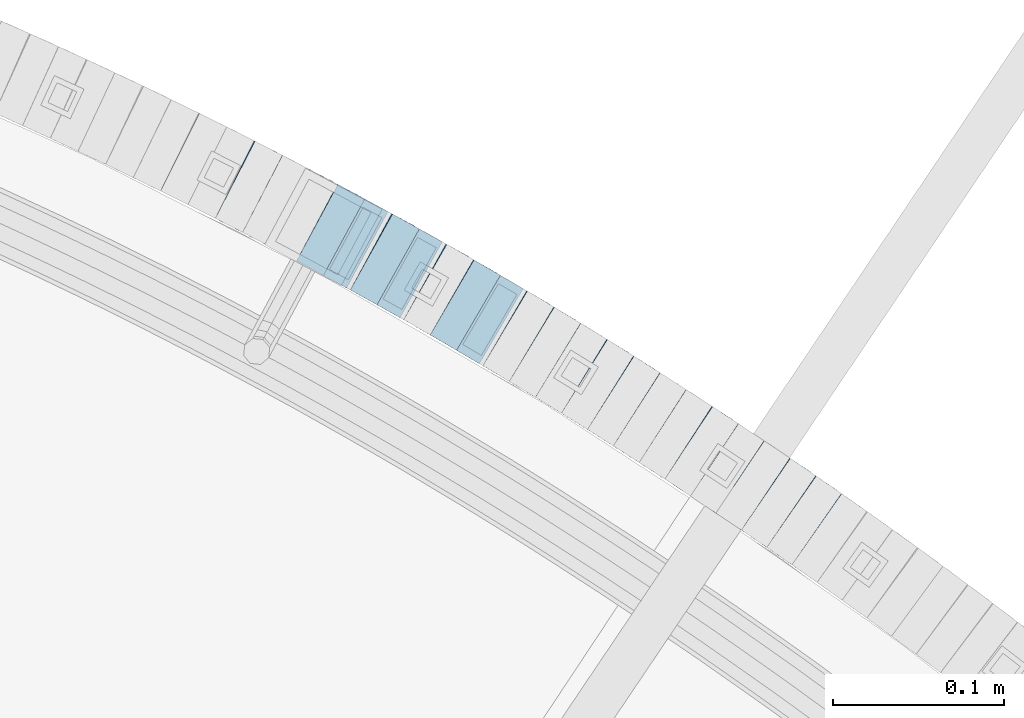
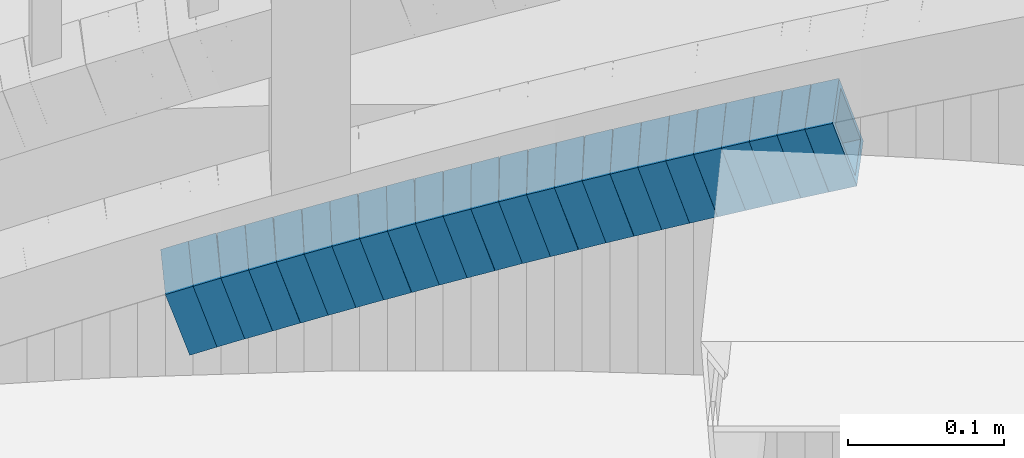
# One storey, part 810 of 975: 24 beams.
"""IFC2X3 building model written with IfcOpenShell, lengths in millimetres."""

from ifc_helpers import new_model, si_unit, frame, origin_with_axes, place, context, subcontext, project, spatial, faceted_brep, material, type_object, element, save


model = new_model("IFC2X3")

# Units and contexts
model_context = context("Model", 3, precision=1e-05, world=origin_with_axes())
body_context = subcontext(model_context, "Body", "Model", "MODEL_VIEW")
ifc_project = project(units=[si_unit("LENGTHUNIT", "METRE", prefix="MILLI"), si_unit("AREAUNIT", "SQUARE_METRE"), si_unit("VOLUMEUNIT", "CUBIC_METRE"), si_unit("MASSUNIT", "GRAM", prefix="KILO"), si_unit("TIMEUNIT", "SECOND"), si_unit("PLANEANGLEUNIT", "RADIAN"), si_unit("SOLIDANGLEUNIT", "STERADIAN"), si_unit("THERMODYNAMICTEMPERATUREUNIT", "DEGREE_CELSIUS"), si_unit("LUMINOUSINTENSITYUNIT", "LUMEN")], contexts=[model_context])

# Site, building, storey
site_placement = place(None, origin_with_axes())
site = spatial("IfcSite", under=ifc_project, at=site_placement, CompositionType="ELEMENT")
building_placement = place(site_placement, origin_with_axes())
building = spatial("IfcBuilding", under=site, at=building_placement, Name="Undefined", CompositionType="ELEMENT")
storey_placement = place(building_placement, origin_with_axes())
storey = spatial("IfcBuildingStorey", under=building, at=storey_placement, Name="Undefined", CompositionType="ELEMENT", Elevation=0.0)

# Beams
ifc_material = material()
beam_type = type_object("IfcBeamType", Name="HSS2X2X.188_TUBES", PredefinedType="NOTDEFINED")
beam_1_placement = place(storey_placement, frame((36384.6907357374, 5752.46071901437, 1599.03780400066), z_axis=(-0.570081547875678, -0.821588113820831, 0.0), x_axis=(-0.781550119844927, 0.542300082892293, -0.308366713938766)))
element("IfcBeam", 1, at=beam_1_placement, inside=storey, type_object=beam_type, material=ifc_material, Name="WALL", ObjectType="HSS2X2X.188_TUBES", context=body_context, shape_type="Brep", body=[
    faceted_brep([(0.0, 20.6374999999753, -20.6375000000298), (0.0, -20.6375000000153, -20.6375000000153), (18.8066477608099, -20.6374999999862, -20.6375000000116), (18.8066477608172, 20.6375000000062, -20.6374999999971), (0.0, -20.6374999999825, 20.6375000000335), (18.8066477608463, -20.6375000000062, 20.6375000000407), (0.0, 20.6375000000116, 20.6375000000189), (18.8066477608536, 20.6374999999844, 20.637500000048), (0.0, 25.3999999999724, -25.4000000000342), (0.0, 25.400000000016, 25.4000000000196), (18.8066477608591, 25.3999999999814, 25.400000000056), (18.8066477608154, 25.4000000000051, -25.4000000000015), (0.0, -25.399999999976, 25.4000000000378), (18.8066477608518, -25.4000000000087, 25.4000000000451), (0.0, -25.400000000016, -25.4000000000196), (18.8066477608081, -25.3999999999851, -25.4000000000196)], [[[0, 1, 2, 3]], [[1, 4, 5, 2]], [[4, 6, 7, 5]], [[6, 0, 3, 7]], [[8, 9, 10, 11]], [[9, 12, 13, 10]], [[12, 14, 15, 13]], [[14, 8, 11, 15]], [[13, 15, 11, 10], [5, 7, 3, 2]], [[14, 12, 9, 8], [6, 4, 1, 0]]]),
])
beam_2_placement = place(storey_placement, frame((36369.7532257072, 5762.89738159828, 1593.19524033732), z_axis=(-0.563683128984149, -0.825991119866696, -1.97385361389024e-11), x_axis=(-0.787122698810591, 0.537158057870632, -0.303148606927001)))
element("IfcBeam", 2, at=beam_2_placement, inside=storey, type_object=beam_type, material=ifc_material, Name="WALL", ObjectType="HSS2X2X.188_TUBES", context=body_context, shape_type="Brep", body=[
    faceted_brep([(0.0, 20.6374999999753, -20.6375000000298), (0.0, -20.6375000000153, -20.6375000000153), (18.8047866246379, -20.6374999999916, -20.6375000000298), (18.8047866247143, 20.6374999999844, -20.6374999999643), (0.0, -20.6374999999825, 20.6375000000335), (18.8047866247107, -20.6375000000189, 20.6375000000407), (0.0, 20.6375000000116, 20.6375000000189), (18.8047866247907, 20.6374999999589, 20.6375000001026), (0.0, 25.3999999999724, -25.4000000000342), (0.0, 25.400000000016, 25.4000000000196), (18.8047866248016, 25.3999999999542, 25.4000000001142), (18.8047866247143, 25.3999999999851, -25.3999999999651), (0.0, -25.399999999976, 25.4000000000378), (18.8047866247107, -25.4000000000196, 25.4000000000415), (0.0, -25.400000000016, -25.4000000000196), (18.8047866246197, -25.3999999999887, -25.4000000000378)], [[[0, 1, 2, 3]], [[1, 4, 5, 2]], [[4, 6, 7, 5]], [[6, 0, 3, 7]], [[8, 9, 10, 11]], [[9, 12, 13, 10]], [[12, 14, 15, 13]], [[14, 8, 11, 15]], [[13, 15, 11, 10], [5, 7, 3, 2]], [[14, 12, 9, 8], [6, 4, 1, 0]]]),
])
beam_3_placement = place(storey_placement, frame((36354.8150801214, 5773.16282920866, 1587.4919238903), z_axis=(-0.557269558884145, -0.830331643827375, 0.0), x_axis=(-0.791367387048829, 0.531119052032849, -0.302737859018717)))
element("IfcBeam", 3, at=beam_3_placement, inside=storey, type_object=beam_type, material=ifc_material, Name="WALL", ObjectType="HSS2X2X.188_TUBES", context=body_context, shape_type="Brep", body=[
    faceted_brep([(0.0, 20.6374999999753, -20.6375000000298), (0.0, -20.6375000000153, -20.6375000000153), (18.8332159191086, -20.6374999999916, -20.6375000000153), (18.8332159190923, 20.6375000000062, -20.6375000000335), (0.0, -20.6374999999825, 20.6375000000335), (18.8332159191377, -20.6375000000062, 20.6375000000335), (0.0, 20.6375000000116, 20.6375000000189), (18.8332159191141, 20.6374999999916, 20.6375000000116), (0.0, 25.3999999999724, -25.4000000000342), (0.0, 25.400000000016, 25.4000000000196), (18.8332159191159, 25.3999999999905, 25.4000000000124), (18.8332159190886, 25.4000000000069, -25.4000000000415), (0.0, -25.399999999976, 25.4000000000378), (18.8332159191395, -25.4000000000069, 25.4000000000378), (0.0, -25.400000000016, -25.4000000000196), (18.8332159191104, -25.3999999999905, -25.400000000016)], [[[0, 1, 2, 3]], [[1, 4, 5, 2]], [[4, 6, 7, 5]], [[6, 0, 3, 7]], [[8, 9, 10, 11]], [[9, 12, 13, 10]], [[12, 14, 15, 13]], [[14, 8, 11, 15]], [[13, 15, 11, 10], [5, 7, 3, 2]], [[14, 12, 9, 8], [6, 4, 1, 0]]]),
])
beam_4_placement = place(storey_placement, frame((36339.9569542748, 5783.17818675861, 1581.83819886342), z_axis=(-0.553409530274032, -0.832909293862108, 1.71302190210554e-10), x_axis=(-0.792306643130973, 0.526431930087055, -0.308414666050996)))
element("IfcBeam", 4, at=beam_4_placement, inside=storey, type_object=beam_type, material=ifc_material, Name="WALL", ObjectType="HSS2X2X.188_TUBES", context=body_context, shape_type="Brep", body=[
    faceted_brep([(0.0, 20.6374999999753, -20.6375000000298), (0.0, -20.6375000000153, -20.6375000000153), (18.8066477608099, -20.6374999999862, -20.6375000000116), (18.8066477608172, 20.6375000000062, -20.6374999999971), (0.0, -20.6374999999825, 20.6375000000335), (18.8066477608463, -20.6375000000062, 20.6375000000407), (0.0, 20.6375000000116, 20.6375000000189), (18.8066477608536, 20.6374999999844, 20.637500000048), (0.0, 25.3999999999724, -25.4000000000342), (0.0, 25.400000000016, 25.4000000000196), (18.8066477608591, 25.3999999999814, 25.400000000056), (18.8066477608154, 25.4000000000051, -25.4000000000015), (0.0, -25.399999999976, 25.4000000000378), (18.8066477608518, -25.4000000000087, 25.4000000000451), (0.0, -25.400000000016, -25.4000000000196), (18.8066477608081, -25.3999999999851, -25.4000000000196)], [[[0, 1, 2, 3]], [[1, 4, 5, 2]], [[4, 6, 7, 5]], [[6, 0, 3, 7]], [[8, 9, 10, 11]], [[9, 12, 13, 10]], [[12, 14, 15, 13]], [[14, 8, 11, 15]], [[13, 15, 11, 10], [5, 7, 3, 2]], [[14, 12, 9, 8], [6, 4, 1, 0]]]),
])
beam_5_placement = place(storey_placement, frame((36324.9775984991, 5793.15960759639, 1576.02755470114), z_axis=(-0.550842208647948, -0.834609406352367, -2.89645413431572e-10), x_axis=(-0.794273631185649, 0.524220597122489, -0.307119137071763)))
element("IfcBeam", 5, at=beam_5_placement, inside=storey, type_object=beam_type, material=ifc_material, Name="WALL", ObjectType="HSS2X2X.188_TUBES", context=body_context, shape_type="Brep", body=[
    faceted_brep([(0.0, 20.6374999999753, -20.6375000000298), (0.0, -20.6375000000153, -20.6375000000153), (18.891267824034, -20.6375000000153, -20.6374999999971), (18.891267824034, 20.6375000000025, -20.637500000008), (0.0, -20.6374999999825, 20.6375000000335), (18.8912678240486, -20.6374999999989, 20.6375000000153), (0.0, 20.6375000000116, 20.6375000000189), (18.8912678240449, 20.6375000000189, 20.6375000000007), (0.0, 25.3999999999724, -25.4000000000342), (0.0, 25.400000000016, 25.4000000000196), (18.8912678240467, 25.4000000000215, 25.4000000000051), (18.8912678240304, 25.4000000000033, -25.4000000000124), (0.0, -25.399999999976, 25.4000000000378), (18.8912678240504, -25.3999999999996, 25.400000000016), (0.0, -25.400000000016, -25.4000000000196), (18.891267824034, -25.4000000000178, -25.3999999999978)], [[[0, 1, 2, 3]], [[1, 4, 5, 2]], [[4, 6, 7, 5]], [[6, 0, 3, 7]], [[8, 9, 10, 11]], [[9, 12, 13, 10]], [[12, 14, 15, 13]], [[14, 8, 11, 15]], [[13, 15, 11, 10], [5, 7, 3, 2]], [[14, 12, 9, 8], [6, 4, 1, 0]]]),
])
beam_6_placement = place(storey_placement, frame((36294.6725001844, 5813.07259851732, 1564.49161391714), z_axis=(-0.540475947868087, -0.841359465256137, 7.92160790297203e-11), x_axis=(-0.801887983516062, 0.515120095331611, -0.302699437194877)))
element("IfcBeam", 6, at=beam_6_placement, inside=storey, type_object=beam_type, material=ifc_material, Name="WALL", ObjectType="HSS2X2X.188_TUBES", context=body_context, shape_type="Brep", body=[
    faceted_brep([(0.0, 20.6374999999753, -20.6375000000298), (0.0, -20.6375000000153, -20.6375000000153), (18.8332159191086, -20.6374999999916, -20.6375000000153), (18.8332159190923, 20.6375000000062, -20.6375000000335), (0.0, -20.6374999999825, 20.6375000000335), (18.8332159191377, -20.6375000000062, 20.6375000000335), (0.0, 20.6375000000116, 20.6375000000189), (18.8332159191141, 20.6374999999916, 20.6375000000116), (0.0, 25.3999999999724, -25.4000000000342), (0.0, 25.400000000016, 25.4000000000196), (18.8332159191159, 25.3999999999905, 25.4000000000124), (18.8332159190886, 25.4000000000069, -25.4000000000415), (0.0, -25.399999999976, 25.4000000000378), (18.8332159191395, -25.4000000000069, 25.4000000000378), (0.0, -25.400000000016, -25.4000000000196), (18.8332159191104, -25.3999999999905, -25.400000000016)], [[[0, 1, 2, 3]], [[1, 4, 5, 2]], [[4, 6, 7, 5]], [[6, 0, 3, 7]], [[8, 9, 10, 11]], [[9, 12, 13, 10]], [[12, 14, 15, 13]], [[14, 8, 11, 15]], [[13, 15, 11, 10], [5, 7, 3, 2]], [[14, 12, 9, 8], [6, 4, 1, 0]]]),
])
beam_7_placement = place(storey_placement, frame((36309.7520727599, 5803.29357680818, 1570.20206908369), z_axis=(-0.543019139851262, -0.839720318770003, 0.0), x_axis=(-0.799980089763552, 0.517320457847209, -0.303992433910211)))
element("IfcBeam", 7, at=beam_7_placement, inside=storey, type_object=beam_type, material=ifc_material, Name="WALL", ObjectType="HSS2X2X.188_TUBES", context=body_context, shape_type="Brep", body=[
    faceted_brep([(0.0, 20.6374999999753, -20.6375000000298), (0.0, -20.6375000000153, -20.6375000000153), (18.7547327359644, -20.6374999999844, -20.6375000000553), (18.7547327359898, 20.6375000000171, -20.6375000000335), (0.0, -20.6374999999825, 20.6375000000335), (18.7547327360044, -20.6374999999953, 20.6374999999898), (0.0, 20.6375000000116, 20.6375000000189), (18.7547327360262, 20.6375000000062, 20.6375000000116), (0.0, 25.3999999999724, -25.4000000000342), (0.0, 25.400000000016, 25.4000000000196), (18.7547327360371, 25.4000000000033, 25.4000000000124), (18.7547327359898, 25.4000000000178, -25.4000000000342), (0.0, -25.399999999976, 25.4000000000378), (18.7547327360044, -25.399999999996, 25.3999999999869), (0.0, -25.400000000016, -25.4000000000196), (18.7547327359498, -25.3999999999814, -25.4000000000597)], [[[0, 1, 2, 3]], [[1, 4, 5, 2]], [[4, 6, 7, 5]], [[6, 0, 3, 7]], [[8, 9, 10, 11]], [[9, 12, 13, 10]], [[12, 14, 15, 13]], [[14, 8, 11, 15]], [[13, 15, 11, 10], [5, 7, 3, 2]], [[14, 12, 9, 8], [6, 4, 1, 0]]]),
])
for number, where, z_axis, x_axis, name in (
    (8, (36264.2648869006, 5832.61711595504, 1552.99440949527), (-0.529998940003178, -0.84799830400509, 0.0), (-0.808122035968236, 0.505076271980263, -0.303045762988155), "WALL"),
    (9, (36279.6124337003, 5822.79038310933, 1558.83766047636), (-0.536513821821304, -0.843891532718926, 0.0), (-0.802771407025945, 0.510371226016451, -0.308349282009945), "WALL"),
):
    element("IfcBeam", number, at=place(storey_placement, frame(where, z_axis=z_axis, x_axis=x_axis)), inside=storey, type_object=beam_type, material=ifc_material, Name=name, ObjectType="HSS2X2X.188_TUBES", context=body_context, shape_type="Brep", body=[
        faceted_brep([(0.0, 20.6374999999753, -20.6375000000298), (0.0, -20.6375000000153, -20.6375000000153), (18.8066477608099, -20.6374999999862, -20.6375000000116), (18.8066477608172, 20.6375000000062, -20.6374999999971), (0.0, -20.6374999999825, 20.6375000000335), (18.8066477608463, -20.6375000000062, 20.6375000000407), (0.0, 20.6375000000116, 20.6375000000189), (18.8066477608536, 20.6374999999844, 20.637500000048), (0.0, 25.3999999999724, -25.4000000000342), (0.0, 25.400000000016, 25.4000000000196), (18.8066477608591, 25.3999999999814, 25.400000000056), (18.8066477608154, 25.4000000000051, -25.4000000000015), (0.0, -25.399999999976, 25.4000000000378), (18.8066477608518, -25.4000000000087, 25.4000000000451), (0.0, -25.400000000016, -25.4000000000196), (18.8066477608081, -25.3999999999851, -25.4000000000196)], [[[0, 1, 2, 3]], [[1, 4, 5, 2]], [[4, 6, 7, 5]], [[6, 0, 3, 7]], [[8, 9, 10, 11]], [[9, 12, 13, 10]], [[12, 14, 15, 13]], [[14, 8, 11, 15]], [[13, 15, 11, 10], [5, 7, 3, 2]], [[14, 12, 9, 8], [6, 4, 1, 0]]]),
    ])
beam_8_placement = place(storey_placement, frame((36249.0377792218, 5842.22093649968, 1547.34720505235), z_axis=(-0.52190392994789, -0.853004271914829, 0.0), x_axis=(-0.811119578118518, 0.496277110072541, -0.309506155045233)))
element("IfcBeam", 10, at=beam_8_placement, inside=storey, type_object=beam_type, material=ifc_material, Name="WALL", ObjectType="HSS2X2X.188_TUBES", context=body_context, shape_type="Brep", body=[
    faceted_brep([(0.0, 20.6374999999753, -20.6375000000298), (0.0, -20.6375000000153, -20.6375000000153), (18.7416648140024, -20.6375000000153, -20.6374999999825), (18.7416648139188, 20.6375000000189, -20.6375000000298), (0.0, -20.6374999999825, 20.6375000000335), (18.7416648140097, -20.6375000000189, 20.6375000000226), (0.0, 20.6375000000116, 20.6375000000189), (18.741664813926, 20.6375000000153, 20.6374999999753), (0.0, 25.3999999999724, -25.4000000000342), (0.0, 25.400000000016, 25.4000000000196), (18.7416648139224, 25.4000000000196, 25.3999999999687), (18.7416648139042, 25.4000000000233, -25.4000000000378), (0.0, -25.399999999976, 25.4000000000378), (18.7416648140133, -25.4000000000215, 25.4000000000269), (0.0, -25.400000000016, -25.4000000000196), (18.7416648140133, -25.4000000000196, -25.399999999976)], [[[0, 1, 2, 3]], [[1, 4, 5, 2]], [[4, 6, 7, 5]], [[6, 0, 3, 7]], [[8, 9, 10, 11]], [[9, 12, 13, 10]], [[12, 14, 15, 13]], [[14, 8, 11, 15]], [[13, 15, 11, 10], [5, 7, 3, 2]], [[14, 12, 9, 8], [6, 4, 1, 0]]]),
])
beam_9_placement = place(storey_placement, frame((36233.6528873879, 5851.6602645125, 1541.49687075694), z_axis=(-0.519415298092855, -0.854521941267227, 1.89281763596227e-11), x_axis=(-0.814256102080023, 0.494939984048714, -0.303350313029847)))
element("IfcBeam", 11, at=beam_9_placement, inside=storey, type_object=beam_type, material=ifc_material, Name="WALL", ObjectType="HSS2X2X.188_TUBES", context=body_context, shape_type="Brep", body=[
    faceted_brep([(0.0, 20.6374999999753, -20.6375000000298), (0.0, -20.6375000000153, -20.6375000000153), (18.7853666454903, -20.6375000000535, -20.6375000000326), (18.785366645363, 20.6374999999862, -20.6375000000044), (0.0, -20.6374999999825, 20.6375000000335), (18.785366645352, -20.6375000000007, 20.6374999999989), (0.0, 20.6375000000116, 20.6375000000189), (18.7853666453102, 20.6375000000025, 20.6374999999753), (0.0, 25.3999999999724, -25.4000000000342), (0.0, 25.400000000016, 25.4000000000196), (18.7853666452065, 25.4000000000451, 25.4000000000351), (18.7853666453739, 25.3999999999833, -25.400000000006), (0.0, -25.399999999976, 25.4000000000378), (18.7853666497213, -25.399999993424, 25.3999999995158), (0.0, -25.400000000016, -25.4000000000196), (18.7853666455194, -25.4000000000633, -25.4000000000406)], [[[0, 1, 2, 3]], [[1, 4, 5, 2]], [[4, 6, 7, 5]], [[6, 0, 3, 7]], [[8, 9, 10, 11]], [[9, 12, 13, 10]], [[12, 14, 15, 13]], [[14, 8, 11, 15]], [[13, 15, 11, 10], [5, 7, 3, 2]], [[14, 12, 9, 8], [6, 4, 1, 0]]]),
])
beam_10_placement = place(storey_placement, frame((36218.2053230806, 5861.11802997809, 1535.79264778822), z_axis=(-0.512855252011235, -0.858475096018803, 0.0), x_axis=(-0.818165709651485, 0.488774319791708, -0.302827567870951)))
element("IfcBeam", 12, at=beam_10_placement, inside=storey, type_object=beam_type, material=ifc_material, Name="WALL", ObjectType="HSS2X2X.188_TUBES", context=body_context, shape_type="Brep", body=[
    faceted_brep([(0.0, 20.6374999999753, -20.6375000000298), (0.0, -20.6375000000153, -20.6375000000153), (18.8225928075335, -20.6374999999935, -20.6375000000298), (18.8225928075699, 20.6374999999898, -20.6374999999825), (0.0, -20.6374999999825, 20.6375000000335), (18.8225928075772, -20.637500000008, 20.6375000000226), (0.0, 20.6375000000116, 20.6375000000189), (18.8225928076135, 20.6374999999753, 20.6375000000698), (0.0, 25.3999999999724, -25.4000000000342), (0.0, 25.400000000016, 25.4000000000196), (18.8225928076281, 25.3999999999705, 25.4000000000815), (18.8225928075663, 25.3999999999905, -25.3999999999796), (0.0, -25.399999999976, 25.4000000000378), (18.8225928075808, -25.4000000000087, 25.4000000000233), (0.0, -25.400000000016, -25.4000000000196), (18.8225928075226, -25.3999999999905, -25.4000000000378)], [[[0, 1, 2, 3]], [[1, 4, 5, 2]], [[4, 6, 7, 5]], [[6, 0, 3, 7]], [[8, 9, 10, 11]], [[9, 12, 13, 10]], [[12, 14, 15, 13]], [[14, 8, 11, 15]], [[13, 15, 11, 10], [5, 7, 3, 2]], [[14, 12, 9, 8], [6, 4, 1, 0]]]),
])
beam_11_placement = place(storey_placement, frame((36202.7728720069, 5870.42411417233, 1530.14491401188), z_axis=(-0.504568019130195, -0.863371944222785, 0.0), x_axis=(-0.821056045766428, 0.479837948863549, -0.309228899912056)))
element("IfcBeam", 13, at=beam_11_placement, inside=storey, type_object=beam_type, material=ifc_material, Name="WALL", ObjectType="HSS2X2X.188_TUBES", context=body_context, shape_type="Brep", body=[
    faceted_brep([(0.0, 20.6374999999753, -20.6375000000298), (0.0, -20.6375000000153, -20.6375000000153), (18.7555325170906, -20.6374999999916, -20.6374999999971), (18.7555325171452, 20.637499999988, -20.6374999999571), (0.0, -20.6374999999825, 20.6375000000335), (18.7555325170615, -20.6374999999844, 20.6374999999716), (0.0, 20.6375000000116, 20.6375000000189), (18.7555325171015, 20.6374999999953, 20.637500000008), (0.0, 25.3999999999724, -25.4000000000342), (0.0, 25.400000000016, 25.4000000000196), (18.7555325171015, 25.399999999996, 25.4000000000051), (18.7555325171488, 25.3999999999851, -25.3999999999505), (0.0, -25.399999999976, 25.4000000000378), (18.755532517047, -25.3999999999814, 25.3999999999578), (0.0, -25.400000000016, -25.4000000000196), (18.7555325170979, -25.3999999999924, -25.3999999999978)], [[[0, 1, 2, 3]], [[1, 4, 5, 2]], [[4, 6, 7, 5]], [[6, 0, 3, 7]], [[8, 9, 10, 11]], [[9, 12, 13, 10]], [[12, 14, 15, 13]], [[14, 8, 11, 15]], [[13, 15, 11, 10], [5, 7, 3, 2]], [[14, 12, 9, 8], [6, 4, 1, 0]]]),
])
beam_12_placement = place(storey_placement, frame((36187.2668727273, 5879.48606180324, 1524.30533664048), z_axis=(-0.504568019130195, -0.863371944222785, 0.0), x_axis=(-0.822401320838002, 0.480624148905402, -0.30439529394008)))
element("IfcBeam", 14, at=beam_12_placement, inside=storey, type_object=beam_type, material=ifc_material, Name="WALL", ObjectType="HSS2X2X.188_TUBES", context=body_context, shape_type="Brep", body=[
    faceted_brep([(0.0, 20.6374999999753, -20.6375000000298), (0.0, -20.6375000000153, -20.6375000000153), (18.7347271129966, -20.6375000000116, -20.6375000000262), (18.7347271130257, 20.6374999999989, -20.6374999999935), (0.0, -20.6374999999825, 20.6375000000335), (18.7347271129947, -20.6375000000116, 20.6374999999607), (0.0, 20.6375000000116, 20.6375000000189), (18.7347271130147, 20.6375000000007, 20.6374999999898), (0.0, 25.3999999999724, -25.4000000000342), (0.0, 25.400000000016, 25.4000000000196), (18.7347271130166, 25.4000000000015, 25.3999999999905), (18.7347271130257, 25.3999999999996, -25.3999999999869), (0.0, -25.399999999976, 25.4000000000378), (18.7347271129875, -25.4000000000106, 25.3999999999505), (0.0, -25.400000000016, -25.4000000000196), (18.7347271130002, -25.4000000000124, -25.4000000000233)], [[[0, 1, 2, 3]], [[1, 4, 5, 2]], [[4, 6, 7, 5]], [[6, 0, 3, 7]], [[8, 9, 10, 11]], [[9, 12, 13, 10]], [[12, 14, 15, 13]], [[14, 8, 11, 15]], [[13, 15, 11, 10], [5, 7, 3, 2]], [[14, 12, 9, 8], [6, 4, 1, 0]]]),
])
beam_13_placement = place(storey_placement, frame((36171.7159265763, 5888.64182691282, 1518.60077401145), z_axis=(-0.497945444086888, -0.867208357151332, 0.0), x_axis=(-0.826211457590197, 0.474405288764631, -0.303832600849267)))
element("IfcBeam", 15, at=beam_13_placement, inside=storey, type_object=beam_type, material=ifc_material, Name="WALL", ObjectType="HSS2X2X.188_TUBES", context=body_context, shape_type="Brep", body=[
    faceted_brep([(0.0, 20.6374999999753, -20.6375000000298), (0.0, -20.6375000000153, -20.6375000000153), (18.7555325170906, -20.6374999999916, -20.6374999999971), (18.7555325171452, 20.637499999988, -20.6374999999571), (0.0, -20.6374999999825, 20.6375000000335), (18.7555325170615, -20.6374999999844, 20.6374999999716), (0.0, 20.6375000000116, 20.6375000000189), (18.7555325171015, 20.6374999999953, 20.637500000008), (0.0, 25.3999999999724, -25.4000000000342), (0.0, 25.400000000016, 25.4000000000196), (18.7555325171015, 25.399999999996, 25.4000000000051), (18.7555325171488, 25.3999999999851, -25.3999999999505), (0.0, -25.399999999976, 25.4000000000378), (18.755532517047, -25.3999999999814, 25.3999999999578), (0.0, -25.400000000016, -25.4000000000196), (18.7555325170979, -25.3999999999924, -25.3999999999978)], [[[0, 1, 2, 3]], [[1, 4, 5, 2]], [[4, 6, 7, 5]], [[6, 0, 3, 7]], [[8, 9, 10, 11]], [[9, 12, 13, 10]], [[12, 14, 15, 13]], [[14, 8, 11, 15]], [[13, 15, 11, 10], [5, 7, 3, 2]], [[14, 12, 9, 8], [6, 4, 1, 0]]]),
])
beam_14_placement = place(storey_placement, frame((36156.0981996203, 5897.72018910054, 1512.94169177912), z_axis=(-0.487068314604723, -0.87336387428615, 1.57352815222112e-10), x_axis=(-0.83066904229901, 0.463257735166798, -0.308838490111215)))
element("IfcBeam", 16, at=beam_14_placement, inside=storey, type_object=beam_type, material=ifc_material, Name="WALL", ObjectType="HSS2X2X.188_TUBES", context=body_context, shape_type="Brep", body=[
    faceted_brep([(0.0, 20.6374999999753, -20.6375000000298), (0.0, -20.6375000000153, -20.6375000000153), (18.7771137292038, -20.637500000008, -20.6374999999862), (18.777113729182, 20.6375000000062, -20.6375000000189), (0.0, -20.6374999999825, 20.6375000000335), (18.7771137291729, -20.6374999999916, 20.6374999999753), (0.0, 20.6375000000116, 20.6375000000189), (18.7771137291529, 20.6375000000207, 20.6374999999389), (0.0, 25.3999999999724, -25.4000000000342), (0.0, 25.400000000016, 25.4000000000196), (18.7771137291475, 25.4000000000251, 25.3999999999287), (18.7771137291857, 25.4000000000051, -25.4000000000196), (0.0, -25.399999999976, 25.4000000000378), (18.7771137291711, -25.3999999999905, 25.3999999999724), (0.0, -25.400000000016, -25.4000000000196), (18.7771137292129, -25.4000000000124, -25.3999999999724)], [[[0, 1, 2, 3]], [[1, 4, 5, 2]], [[4, 6, 7, 5]], [[6, 0, 3, 7]], [[8, 9, 10, 11]], [[9, 12, 13, 10]], [[12, 14, 15, 13]], [[14, 8, 11, 15]], [[13, 15, 11, 10], [5, 7, 3, 2]], [[14, 12, 9, 8], [6, 4, 1, 0]]]),
])
beam_15_placement = place(storey_placement, frame((36140.3910810649, 5906.47992829489, 1507.10220925853), z_axis=(-0.487068314604723, -0.87336387428615, 1.57352815222112e-10), x_axis=(-0.832026625199708, 0.464014849111326, -0.304009728072931)))
element("IfcBeam", 17, at=beam_15_placement, inside=storey, type_object=beam_type, material=ifc_material, Name="WALL", ObjectType="HSS2X2X.188_TUBES", context=body_context, shape_type="Brep", body=[
    faceted_brep([(0.0, 20.6374999999753, -20.6375000000298), (0.0, -20.6375000000153, -20.6375000000153), (18.7547327359644, -20.6374999999844, -20.6375000000553), (18.7547327359898, 20.6375000000171, -20.6375000000335), (0.0, -20.6374999999825, 20.6375000000335), (18.7547327360044, -20.6374999999953, 20.6374999999898), (0.0, 20.6375000000116, 20.6375000000189), (18.7547327360262, 20.6375000000062, 20.6375000000116), (0.0, 25.3999999999724, -25.4000000000342), (0.0, 25.400000000016, 25.4000000000196), (18.7547327360371, 25.4000000000033, 25.4000000000124), (18.7547327359898, 25.4000000000178, -25.4000000000342), (0.0, -25.399999999976, 25.4000000000378), (18.7547327360044, -25.399999999996, 25.3999999999869), (0.0, -25.400000000016, -25.4000000000196), (18.7547327359498, -25.3999999999814, -25.4000000000597)], [[[0, 1, 2, 3]], [[1, 4, 5, 2]], [[4, 6, 7, 5]], [[6, 0, 3, 7]], [[8, 9, 10, 11]], [[9, 12, 13, 10]], [[12, 14, 15, 13]], [[14, 8, 11, 15]], [[13, 15, 11, 10], [5, 7, 3, 2]], [[14, 12, 9, 8], [6, 4, 1, 0]]]),
])
for number, where, z_axis, x_axis, name in (
    (18, (36124.562080818, 5915.4160367081, 1501.40329672661), (-0.47610269708078, -0.879389687131028, -2.76304490398616e-12), (-0.837729580038729, 0.453547862021041, -0.3041438600141), "WALL"),
    (19, (36108.862080818, 5923.91603670811, 1495.70329672658), (-0.47610269708078, -0.879389687131028, -2.76304490398616e-12), (-0.837729580038729, 0.453547862021041, -0.3041438600141), "WALL"),
):
    element("IfcBeam", number, at=place(storey_placement, frame(where, z_axis=z_axis, x_axis=x_axis)), inside=storey, type_object=beam_type, material=ifc_material, Name=name, ObjectType="HSS2X2X.188_TUBES", context=body_context, shape_type="Brep", body=[
        faceted_brep([(0.0, 20.6374999999753, -20.6375000000298), (0.0, -20.6375000000153, -20.6375000000153), (18.7416648140024, -20.6375000000153, -20.6374999999825), (18.7416648139188, 20.6375000000189, -20.6375000000298), (0.0, -20.6374999999825, 20.6375000000335), (18.7416648140097, -20.6375000000189, 20.6375000000226), (0.0, 20.6375000000116, 20.6375000000189), (18.741664813926, 20.6375000000153, 20.6374999999753), (0.0, 25.3999999999724, -25.4000000000342), (0.0, 25.400000000016, 25.4000000000196), (18.7416648139224, 25.4000000000196, 25.3999999999687), (18.7416648139042, 25.4000000000233, -25.4000000000378), (0.0, -25.399999999976, 25.4000000000378), (18.7416648140133, -25.4000000000215, 25.4000000000269), (0.0, -25.400000000016, -25.4000000000196), (18.7416648140133, -25.4000000000196, -25.399999999976)], [[[0, 1, 2, 3]], [[1, 4, 5, 2]], [[4, 6, 7, 5]], [[6, 0, 3, 7]], [[8, 9, 10, 11]], [[9, 12, 13, 10]], [[12, 14, 15, 13]], [[14, 8, 11, 15]], [[13, 15, 11, 10], [5, 7, 3, 2]], [[14, 12, 9, 8], [6, 4, 1, 0]]]),
    ])
beam_16_placement = place(storey_placement, frame((36093.1142234705, 5932.50858066366, 1490.03755285478), z_axis=(-0.469427601925258, -0.882970965859411, 0.0), x_axis=(-0.839950366198481, 0.446555891105437, -0.308336210072815)))
element("IfcBeam", 20, at=beam_16_placement, inside=storey, type_object=beam_type, material=ifc_material, Name="WALL", ObjectType="HSS2X2X.188_TUBES", context=body_context, shape_type="Brep", body=[
    faceted_brep([(0.0, 20.6374999999753, -20.6375000000298), (0.0, -20.6375000000153, -20.6375000000153), (18.8066477608099, -20.6374999999862, -20.6375000000116), (18.8066477608172, 20.6375000000062, -20.6374999999971), (0.0, -20.6374999999825, 20.6375000000335), (18.8066477608463, -20.6375000000062, 20.6375000000407), (0.0, 20.6375000000116, 20.6375000000189), (18.8066477608536, 20.6374999999844, 20.637500000048), (0.0, 25.3999999999724, -25.4000000000342), (0.0, 25.400000000016, 25.4000000000196), (18.8066477608591, 25.3999999999814, 25.400000000056), (18.8066477608154, 25.4000000000051, -25.4000000000015), (0.0, -25.399999999976, 25.4000000000378), (18.8066477608518, -25.4000000000087, 25.4000000000451), (0.0, -25.400000000016, -25.4000000000196), (18.8066477608081, -25.3999999999851, -25.4000000000196)], [[[0, 1, 2, 3]], [[1, 4, 5, 2]], [[4, 6, 7, 5]], [[6, 0, 3, 7]], [[8, 9, 10, 11]], [[9, 12, 13, 10]], [[12, 14, 15, 13]], [[14, 8, 11, 15]], [[13, 15, 11, 10], [5, 7, 3, 2]], [[14, 12, 9, 8], [6, 4, 1, 0]]]),
])
beam_17_placement = place(storey_placement, frame((36077.0509919536, 5941.13413684581, 1484.20986310048), z_axis=(-0.460645080913193, -0.887584423832729, 0.0), x_axis=(-0.845306642821221, 0.438703447907157, -0.30495239693547)))
element("IfcBeam", 21, at=beam_17_placement, inside=storey, type_object=beam_type, material=ifc_material, Name="WALL", ObjectType="HSS2X2X.188_TUBES", context=body_context, shape_type="Brep", body=[
    faceted_brep([(0.0, 20.6374999999753, -20.6375000000298), (0.0, -20.6375000000153, -20.6375000000153), (18.6895692834223, -20.637499999988, -20.6374999999862), (18.6895692834369, 20.6374999999953, -20.6374999999534), (0.0, -20.6374999999825, 20.6375000000335), (18.6895692833914, -20.637499999988, 20.6374999999789), (0.0, 20.6375000000116, 20.6375000000189), (18.6895692834078, 20.6374999999953, 20.637500000008), (0.0, 25.3999999999724, -25.4000000000342), (0.0, 25.400000000016, 25.4000000000196), (18.6895692834059, 25.3999999999924, 25.4000000000087), (18.6895692834423, 25.3999999999942, -25.3999999999432), (0.0, -25.399999999976, 25.4000000000378), (18.6895692833878, -25.3999999999869, 25.3999999999687), (0.0, -25.400000000016, -25.4000000000196), (18.6895692834241, -25.3999999999869, -25.3999999999833)], [[[0, 1, 2, 3]], [[1, 4, 5, 2]], [[4, 6, 7, 5]], [[6, 0, 3, 7]], [[8, 9, 10, 11]], [[9, 12, 13, 10]], [[12, 14, 15, 13]], [[14, 8, 11, 15]], [[13, 15, 11, 10], [5, 7, 3, 2]], [[14, 12, 9, 8], [6, 4, 1, 0]]]),
])
beam_18_placement = place(storey_placement, frame((36061.1710469872, 5949.39790169671, 1478.49871466278), z_axis=(-0.458358127825704, -0.888767588662028, 0.0), x_axis=(-0.846823544044335, 0.436726608022864, -0.303578252015912)))
element("IfcBeam", 22, at=beam_18_placement, inside=storey, type_object=beam_type, material=ifc_material, Name="WALL", ObjectType="HSS2X2X.188_TUBES", context=body_context, shape_type="Brep", body=[
    faceted_brep([(0.0, 20.6374999999753, -20.6375000000298), (0.0, -20.6375000000153, -20.6375000000153), (18.7771137292038, -20.637500000008, -20.6374999999862), (18.777113729182, 20.6375000000062, -20.6375000000189), (0.0, -20.6374999999825, 20.6375000000335), (18.7771137291729, -20.6374999999916, 20.6374999999753), (0.0, 20.6375000000116, 20.6375000000189), (18.7771137291529, 20.6375000000207, 20.6374999999389), (0.0, 25.3999999999724, -25.4000000000342), (0.0, 25.400000000016, 25.4000000000196), (18.7771137291475, 25.4000000000251, 25.3999999999287), (18.7771137291857, 25.4000000000051, -25.4000000000196), (0.0, -25.399999999976, 25.4000000000378), (18.7771137291711, -25.3999999999905, 25.3999999999724), (0.0, -25.400000000016, -25.4000000000196), (18.7771137292129, -25.4000000000124, -25.3999999999724)], [[[0, 1, 2, 3]], [[1, 4, 5, 2]], [[4, 6, 7, 5]], [[6, 0, 3, 7]], [[8, 9, 10, 11]], [[9, 12, 13, 10]], [[12, 14, 15, 13]], [[14, 8, 11, 15]], [[13, 15, 11, 10], [5, 7, 3, 2]], [[14, 12, 9, 8], [6, 4, 1, 0]]]),
])
beam_19_placement = place(storey_placement, frame((36045.0321055626, 5957.82734525993, 1472.79888890966), z_axis=(-0.447213595899957, -0.894427190799916, 0.0), x_axis=(-0.852209914200112, 0.426104957100104, -0.303599782071325)))
element("IfcBeam", 23, at=beam_19_placement, inside=storey, type_object=beam_type, material=ifc_material, Name="WALL", ObjectType="HSS2X2X.188_TUBES", context=body_context, shape_type="Brep", body=[
    faceted_brep([(0.0, 20.6374999999753, -20.6375000000298), (0.0, -20.6375000000153, -20.6375000000153), (18.767258723612, -20.6375000000025, -20.6374999999862), (18.7672587236229, 20.6374999999953, -20.637499999968), (0.0, -20.6374999999825, 20.6375000000335), (18.767258723612, -20.6375000000135, 20.6375000000153), (0.0, 20.6375000000116, 20.6375000000189), (18.7672587236266, 20.6374999999844, 20.6375000000371), (0.0, 25.3999999999724, -25.4000000000342), (0.0, 25.400000000016, 25.4000000000196), (18.7672587236302, 25.3999999999814, 25.4000000000342), (18.7672587236229, 25.399999999996, -25.3999999999687), (0.0, -25.399999999976, 25.4000000000378), (18.7672587236157, -25.4000000000142, 25.400000000016), (0.0, -25.400000000016, -25.4000000000196), (18.767258723612, -25.4000000000015, -25.3999999999905)], [[[0, 1, 2, 3]], [[1, 4, 5, 2]], [[4, 6, 7, 5]], [[6, 0, 3, 7]], [[8, 9, 10, 11]], [[9, 12, 13, 10]], [[12, 14, 15, 13]], [[14, 8, 11, 15]], [[13, 15, 11, 10], [5, 7, 3, 2]], [[14, 12, 9, 8], [6, 4, 1, 0]]]),
])
beam_20_placement = place(storey_placement, frame((36029.1416904038, 5965.77255283934, 1467.13827068308), z_axis=(-0.447213595899957, -0.894427190799916, 0.0), x_axis=(-0.850823137641027, 0.425411568820562, -0.308423386869911)))
element("IfcBeam", 24, at=beam_20_placement, inside=storey, type_object=beam_type, material=ifc_material, Name="WALL", ObjectType="HSS2X2X.188_TUBES", context=body_context, shape_type="Brep", body=[
    faceted_brep([(0.0, 20.6374999999753, -20.6375000000298), (0.0, -20.6375000000153, -20.6375000000153), (18.8066477608099, -20.6374999999862, -20.6375000000116), (18.8066477608172, 20.6375000000062, -20.6374999999971), (0.0, -20.6374999999825, 20.6375000000335), (18.8066477608463, -20.6375000000062, 20.6375000000407), (0.0, 20.6375000000116, 20.6375000000189), (18.8066477608536, 20.6374999999844, 20.637500000048), (0.0, 25.3999999999724, -25.4000000000342), (0.0, 25.400000000016, 25.4000000000196), (18.8066477608591, 25.3999999999814, 25.400000000056), (18.8066477608154, 25.4000000000051, -25.4000000000015), (0.0, -25.399999999976, 25.4000000000378), (18.8066477608518, -25.4000000000087, 25.4000000000451), (0.0, -25.400000000016, -25.4000000000196), (18.8066477608081, -25.3999999999851, -25.4000000000196)], [[[0, 1, 2, 3]], [[1, 4, 5, 2]], [[4, 6, 7, 5]], [[6, 0, 3, 7]], [[8, 9, 10, 11]], [[9, 12, 13, 10]], [[12, 14, 15, 13]], [[14, 8, 11, 15]], [[13, 15, 11, 10], [5, 7, 3, 2]], [[14, 12, 9, 8], [6, 4, 1, 0]]]),
])

save(model, "model.ifc")
